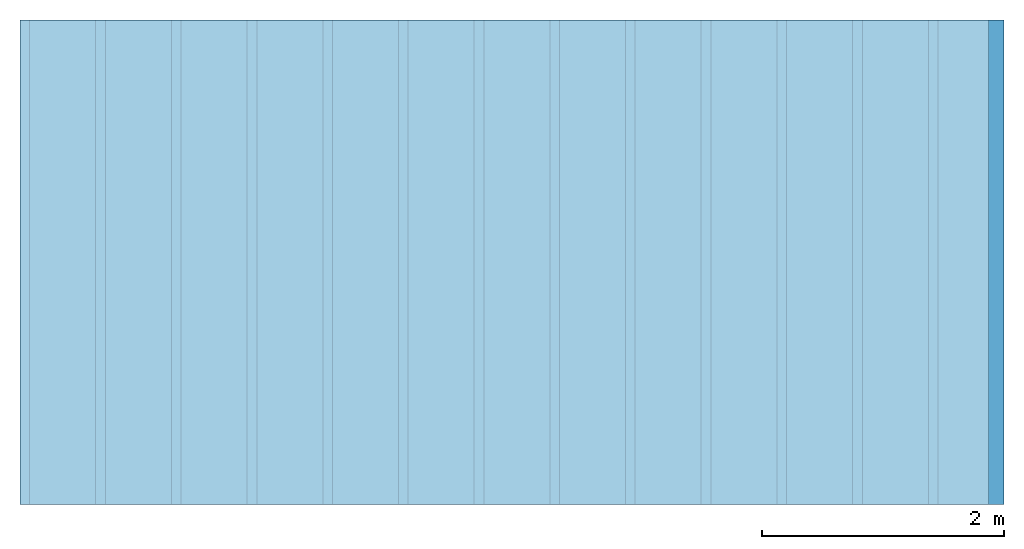
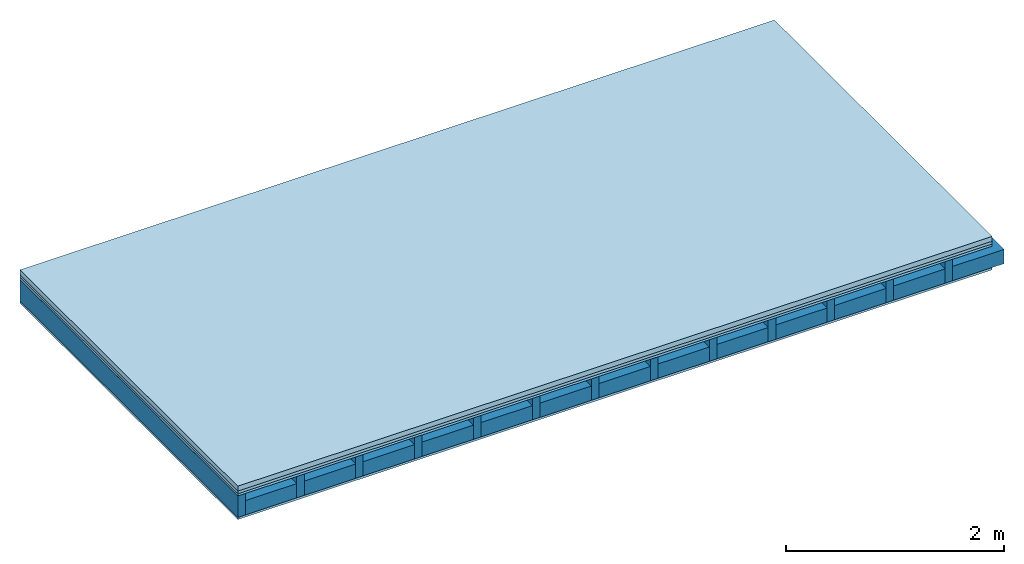
# One storey: 4 plates, 2 members, 1 element without a shape of its own.
"""IFC4 building model written with IfcOpenShell, lengths in metres."""

from ifc_helpers import new_model, si_unit, derived_unit, direction, frame, frame_2d, origin, origin_with_axes, place, context, project, spatial, rectangle, extrude, material, layer, layer_set, type_object, element, aggregate, save


model = new_model("IFC4")

# Units and contexts
plan_context = context("Plan", 3, precision=1e-05, world=origin(), true_north=direction((0.0, 1.0)))
model_context = context("Model", 3, precision=1e-05, world=origin(), true_north=direction((0.0, 1.0)))
ifc_project = project(units=[si_unit("LENGTHUNIT", "METRE"), derived_unit("SOUNDPRESSUREUNIT", [(si_unit("PRESSUREUNIT", "PASCAL", prefix="MICRO"), 0)]), si_unit("ENERGYUNIT", "JOULE", prefix="MEGA"), si_unit("MASSUNIT", "GRAM", prefix="KILO"), derived_unit("THERMALTRANSMITTANCEUNIT", [(si_unit("POWERUNIT", "WATT"), 1), (si_unit("AREAUNIT", "SQUARE_METRE"), -1), (si_unit("THERMODYNAMICTEMPERATUREUNIT", "KELVIN"), -1)]), derived_unit("AREADENSITYUNIT", [(si_unit("MASSUNIT", "GRAM", prefix="KILO"), 1), (si_unit("AREAUNIT", "SQUARE_METRE"), -1)]), derived_unit("USERDEFINED", [(si_unit("ENERGYUNIT", "JOULE", prefix="MEGA"), 1), (si_unit("AREAUNIT", "SQUARE_METRE"), -1)])], contexts=[plan_context, model_context])

# Site, building, storey
site = spatial("IfcSite", under=ifc_project)
building_placement = place(None, origin())
building = spatial("IfcBuilding", under=site, at=building_placement)
storey_placement = place(building_placement, origin())
storey = spatial("IfcBuildingStorey", under=building, at=storey_placement)

# Slab, members, plates
ifc_material_1 = material(Category="04.005")
ifc_layer_1 = layer(ifc_material_1, 0.055, Name="On-material")
ifc_material_2 = material()
ifc_layer_2 = layer(ifc_material_2, 0.03, Name="Impact sound insulation")
ifc_material_3 = material(Category="07.001")
ifc_layer_3 = layer(ifc_material_3, 0.025, Name="Sub-floor")
ifc_material_4 = material(Name="Rigid, of the art")
ifc_layer_4 = layer(ifc_material_4, 0.0, Name="Bond")
ifc_layer_5 = layer(None, 0.24, Name="Supporting structure")
ifc_layer_6 = layer(ifc_material_4, 0.0, Name="Bond")
ifc_layer_7 = layer(ifc_material_3, 0.025, Name="Lower layer 1")
ifc_layer_set = layer_set([ifc_layer_1, ifc_layer_2, ifc_layer_3, ifc_layer_4, ifc_layer_5, ifc_layer_6, ifc_layer_7])
slab_type = type_object("IfcSlabType", Name="A1981", PredefinedType="NOTDEFINED", material=ifc_layer_set)
slab_placement = place(None, frame((0.0, 0.0, 0.0), z_axis=(0.0, 0.0, -1.0), x_axis=(1.0, 0.0, 0.0)))
slab = element("IfcSlab", 1, at=slab_placement, inside=storey, type_object=slab_type, material=ifc_layer_set, Name="Slab #1")
ifc_material_5 = material()
member_1_placement = place(slab_placement, origin())
member_1 = element("IfcMember", 2, at=member_1_placement, material=ifc_material_5, Name="Supporting structure", context=plan_context, shape_type="SweptSolid", body=[
    extrude(rectangle(XDim=0.08, YDim=0.24, at=frame_2d((0.04, 0.12), x_axis=(1.0, 0.0))), frame((0.0, 4.0, 0.11), z_axis=(0.0, -1.0, 0.0), x_axis=(1.0, 0.0, 0.0)), (0.0, 0.0, 1.0), 4.0),
    extrude(rectangle(XDim=0.08, YDim=0.24, at=frame_2d((0.04, 0.12), x_axis=(1.0, 0.0))), frame((0.625, 4.0, 0.11), z_axis=(0.0, -1.0, 0.0), x_axis=(1.0, 0.0, 0.0)), (0.0, 0.0, 1.0), 4.0),
    extrude(rectangle(XDim=0.08, YDim=0.24, at=frame_2d((0.04, 0.12), x_axis=(1.0, 0.0))), frame((1.25, 4.0, 0.11), z_axis=(0.0, -1.0, 0.0), x_axis=(1.0, 0.0, 0.0)), (0.0, 0.0, 1.0), 4.0),
    extrude(rectangle(XDim=0.08, YDim=0.24, at=frame_2d((0.04, 0.12), x_axis=(1.0, 0.0))), frame((1.875, 4.0, 0.11), z_axis=(0.0, -1.0, 0.0), x_axis=(1.0, 0.0, 0.0)), (0.0, 0.0, 1.0), 4.0),
    extrude(rectangle(XDim=0.08, YDim=0.24, at=frame_2d((0.04, 0.12), x_axis=(1.0, 0.0))), frame((2.5, 4.0, 0.11), z_axis=(0.0, -1.0, 0.0), x_axis=(1.0, 0.0, 0.0)), (0.0, 0.0, 1.0), 4.0),
    extrude(rectangle(XDim=0.08, YDim=0.24, at=frame_2d((0.04, 0.12), x_axis=(1.0, 0.0))), frame((3.125, 4.0, 0.11), z_axis=(0.0, -1.0, 0.0), x_axis=(1.0, 0.0, 0.0)), (0.0, 0.0, 1.0), 4.0),
    extrude(rectangle(XDim=0.08, YDim=0.24, at=frame_2d((0.04, 0.12), x_axis=(1.0, 0.0))), frame((3.75, 4.0, 0.11), z_axis=(0.0, -1.0, 0.0), x_axis=(1.0, 0.0, 0.0)), (0.0, 0.0, 1.0), 4.0),
    extrude(rectangle(XDim=0.08, YDim=0.24, at=frame_2d((0.04, 0.12), x_axis=(1.0, 0.0))), frame((4.375, 4.0, 0.11), z_axis=(0.0, -1.0, 0.0), x_axis=(1.0, 0.0, 0.0)), (0.0, 0.0, 1.0), 4.0),
    extrude(rectangle(XDim=0.08, YDim=0.24, at=frame_2d((0.04, 0.12), x_axis=(1.0, 0.0))), frame((5.0, 4.0, 0.11), z_axis=(0.0, -1.0, 0.0), x_axis=(1.0, 0.0, 0.0)), (0.0, 0.0, 1.0), 4.0),
    extrude(rectangle(XDim=0.08, YDim=0.24, at=frame_2d((0.04, 0.12), x_axis=(1.0, 0.0))), frame((5.625, 4.0, 0.11), z_axis=(0.0, -1.0, 0.0), x_axis=(1.0, 0.0, 0.0)), (0.0, 0.0, 1.0), 4.0),
    extrude(rectangle(XDim=0.08, YDim=0.24, at=frame_2d((0.04, 0.12), x_axis=(1.0, 0.0))), frame((6.25, 4.0, 0.11), z_axis=(0.0, -1.0, 0.0), x_axis=(1.0, 0.0, 0.0)), (0.0, 0.0, 1.0), 4.0),
    extrude(rectangle(XDim=0.08, YDim=0.24, at=frame_2d((0.04, 0.12), x_axis=(1.0, 0.0))), frame((6.875, 4.0, 0.11), z_axis=(0.0, -1.0, 0.0), x_axis=(1.0, 0.0, 0.0)), (0.0, 0.0, 1.0), 4.0),
    extrude(rectangle(XDim=0.08, YDim=0.24, at=frame_2d((0.04, 0.12), x_axis=(1.0, 0.0))), frame((7.5, 4.0, 0.11), z_axis=(0.0, -1.0, 0.0), x_axis=(1.0, 0.0, 0.0)), (0.0, 0.0, 1.0), 4.0),
])
ifc_material_6 = material()
member_2_placement = place(slab_placement, origin())
member_2 = element("IfcMember", 3, at=member_2_placement, material=ifc_material_6, Name="Cavity", context=plan_context, shape_type="SweptSolid", body=[
    extrude(rectangle(XDim=0.545, YDim=0.16, at=frame_2d((0.2725, 0.08), x_axis=(1.0, 0.0))), frame((0.08, 4.0, 0.19), z_axis=(0.0, -1.0, 0.0), x_axis=(1.0, 0.0, 0.0)), (0.0, 0.0, 1.0), 4.0),
    extrude(rectangle(XDim=0.545, YDim=0.16, at=frame_2d((0.2725, 0.08), x_axis=(1.0, 0.0))), frame((0.705, 4.0, 0.19), z_axis=(0.0, -1.0, 0.0), x_axis=(1.0, 0.0, 0.0)), (0.0, 0.0, 1.0), 4.0),
    extrude(rectangle(XDim=0.545, YDim=0.16, at=frame_2d((0.2725, 0.08), x_axis=(1.0, 0.0))), frame((1.33, 4.0, 0.19), z_axis=(0.0, -1.0, 0.0), x_axis=(1.0, 0.0, 0.0)), (0.0, 0.0, 1.0), 4.0),
    extrude(rectangle(XDim=0.545, YDim=0.16, at=frame_2d((0.2725, 0.08), x_axis=(1.0, 0.0))), frame((1.955, 4.0, 0.19), z_axis=(0.0, -1.0, 0.0), x_axis=(1.0, 0.0, 0.0)), (0.0, 0.0, 1.0), 4.0),
    extrude(rectangle(XDim=0.545, YDim=0.16, at=frame_2d((0.2725, 0.08), x_axis=(1.0, 0.0))), frame((2.58, 4.0, 0.19), z_axis=(0.0, -1.0, 0.0), x_axis=(1.0, 0.0, 0.0)), (0.0, 0.0, 1.0), 4.0),
    extrude(rectangle(XDim=0.545, YDim=0.16, at=frame_2d((0.2725, 0.08), x_axis=(1.0, 0.0))), frame((3.205, 4.0, 0.19), z_axis=(0.0, -1.0, 0.0), x_axis=(1.0, 0.0, 0.0)), (0.0, 0.0, 1.0), 4.0),
    extrude(rectangle(XDim=0.545, YDim=0.16, at=frame_2d((0.2725, 0.08), x_axis=(1.0, 0.0))), frame((3.83, 4.0, 0.19), z_axis=(0.0, -1.0, 0.0), x_axis=(1.0, 0.0, 0.0)), (0.0, 0.0, 1.0), 4.0),
    extrude(rectangle(XDim=0.545, YDim=0.16, at=frame_2d((0.2725, 0.08), x_axis=(1.0, 0.0))), frame((4.455, 4.0, 0.19), z_axis=(0.0, -1.0, 0.0), x_axis=(1.0, 0.0, 0.0)), (0.0, 0.0, 1.0), 4.0),
    extrude(rectangle(XDim=0.545, YDim=0.16, at=frame_2d((0.2725, 0.08), x_axis=(1.0, 0.0))), frame((5.08, 4.0, 0.19), z_axis=(0.0, -1.0, 0.0), x_axis=(1.0, 0.0, 0.0)), (0.0, 0.0, 1.0), 4.0),
    extrude(rectangle(XDim=0.545, YDim=0.16, at=frame_2d((0.2725, 0.08), x_axis=(1.0, 0.0))), frame((5.705, 4.0, 0.19), z_axis=(0.0, -1.0, 0.0), x_axis=(1.0, 0.0, 0.0)), (0.0, 0.0, 1.0), 4.0),
    extrude(rectangle(XDim=0.545, YDim=0.16, at=frame_2d((0.2725, 0.08), x_axis=(1.0, 0.0))), frame((6.33, 4.0, 0.19), z_axis=(0.0, -1.0, 0.0), x_axis=(1.0, 0.0, 0.0)), (0.0, 0.0, 1.0), 4.0),
    extrude(rectangle(XDim=0.545, YDim=0.16, at=frame_2d((0.2725, 0.08), x_axis=(1.0, 0.0))), frame((6.955, 4.0, 0.19), z_axis=(0.0, -1.0, 0.0), x_axis=(1.0, 0.0, 0.0)), (0.0, 0.0, 1.0), 4.0),
    extrude(rectangle(XDim=0.545, YDim=0.16, at=frame_2d((0.2725, 0.08), x_axis=(1.0, 0.0))), frame((7.58, 4.0, 0.19), z_axis=(0.0, -1.0, 0.0), x_axis=(1.0, 0.0, 0.0)), (0.0, 0.0, 1.0), 4.0),
])
plate_1_placement = place(slab_placement, origin())
plate_1 = element("IfcPlate", 4, at=plate_1_placement, material=ifc_material_1, Name="On-material", context=plan_context, shape_type="SweptSolid", body=[
    extrude(rectangle(XDim=8.0, YDim=4.0, at=frame_2d((4.0, 2.0), x_axis=(1.0, 0.0))), origin_with_axes(), (0.0, 0.0, 1.0), 0.055),
])
plate_2_placement = place(slab_placement, origin())
plate_2 = element("IfcPlate", 5, at=plate_2_placement, material=ifc_material_2, Name="Impact sound insulation", context=plan_context, shape_type="SweptSolid", body=[
    extrude(rectangle(XDim=8.0, YDim=4.0, at=frame_2d((4.0, 2.0), x_axis=(1.0, 0.0))), frame((0.0, 0.0, 0.055), z_axis=(0.0, 0.0, 1.0), x_axis=(1.0, 0.0, 0.0)), (0.0, 0.0, 1.0), 0.03),
])
plate_3_placement = place(slab_placement, origin())
plate_3 = element("IfcPlate", 6, at=plate_3_placement, material=ifc_material_3, Name="Sub-floor", context=plan_context, shape_type="SweptSolid", body=[
    extrude(rectangle(XDim=8.0, YDim=4.0, at=frame_2d((4.0, 2.0), x_axis=(1.0, 0.0))), frame((0.0, 0.0, 0.085), z_axis=(0.0, 0.0, 1.0), x_axis=(1.0, 0.0, 0.0)), (0.0, 0.0, 1.0), 0.025),
])
plate_4_placement = place(slab_placement, origin())
plate_4 = element("IfcPlate", 7, at=plate_4_placement, material=ifc_material_3, Name="Lower layer 1", context=plan_context, shape_type="SweptSolid", body=[
    extrude(rectangle(XDim=8.0, YDim=4.0, at=frame_2d((4.0, 2.0), x_axis=(1.0, 0.0))), frame((0.0, 0.0, 0.35), z_axis=(0.0, 0.0, 1.0), x_axis=(1.0, 0.0, 0.0)), (0.0, 0.0, 1.0), 0.025),
])
aggregate(slab, [plate_1, plate_2, plate_3, member_1, member_2, plate_4])

save(model, "model.ifc")
